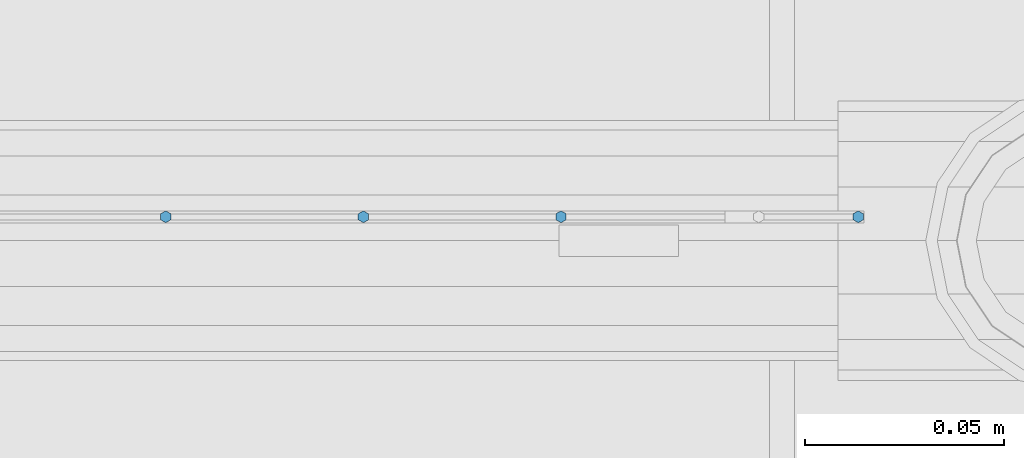
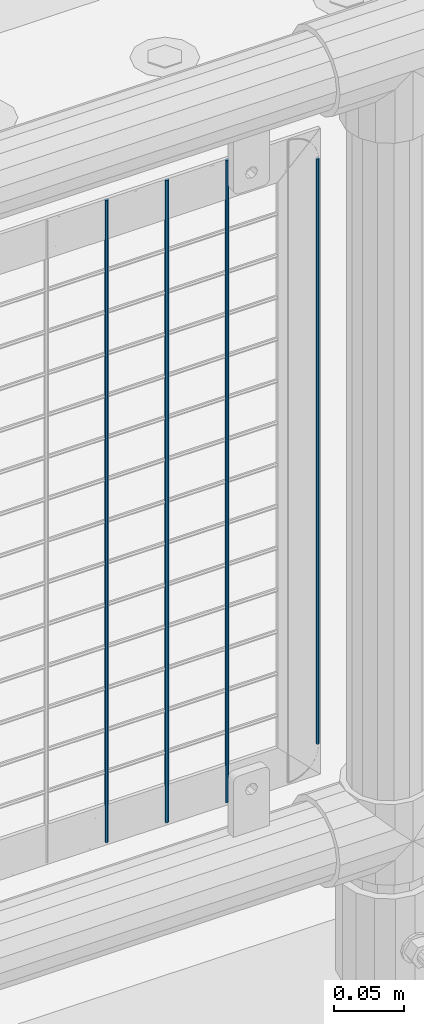
# One storey, part 87 of 257: 4 columns.
"""IFC2X3 building model written with IfcOpenShell, lengths in millimetres."""

from ifc_helpers import new_model, si_unit, frame, origin_with_axes, place, context, subcontext, project, spatial, faceted_brep, material, type_object, element, save


model = new_model("IFC2X3")

# Units and contexts
model_context = context("Model", 3, precision=1e-05, world=origin_with_axes())
body_context = subcontext(model_context, "Body", "Model", "MODEL_VIEW")
ifc_project = project(units=[si_unit("LENGTHUNIT", "METRE", prefix="MILLI"), si_unit("AREAUNIT", "SQUARE_METRE"), si_unit("VOLUMEUNIT", "CUBIC_METRE"), si_unit("MASSUNIT", "GRAM", prefix="KILO"), si_unit("TIMEUNIT", "SECOND"), si_unit("PLANEANGLEUNIT", "RADIAN"), si_unit("SOLIDANGLEUNIT", "STERADIAN"), si_unit("THERMODYNAMICTEMPERATUREUNIT", "DEGREE_CELSIUS"), si_unit("LUMINOUSINTENSITYUNIT", "LUMEN")], contexts=[model_context])

# Site, building, storey
site_placement = place(None, origin_with_axes())
site = spatial("IfcSite", under=ifc_project, at=site_placement, CompositionType="ELEMENT")
building_placement = place(site_placement, origin_with_axes())
building = spatial("IfcBuilding", under=site, at=building_placement, Name="Standard", CompositionType="ELEMENT")
storey_placement = place(building_placement, origin_with_axes())
storey = spatial("IfcBuildingStorey", under=building, at=storey_placement, Name="Undefined", CompositionType="ELEMENT", Elevation=0.0)

# Columns
ifc_material = material(Name="Misc_Undefined")
column_type = type_object("IfcColumnType", Name="D3", PredefinedType="NOTDEFINED")
for number, where, z_axis, x_axis in (
    (1, (52541.34, 10670.5, 353.020000000003), (-1.0, 0.0, 0.0), (0.0, 0.0, 1.0)),
    (2, (52491.685, 10670.5, 353.020000000003), (-1.0, 0.0, 0.0), (0.0, 0.0, 1.0)),
    (3, (52442.03, 10670.5, 353.020000000003), (-1.0, 0.0, 0.0), (0.0, 0.0, 1.0)),
):
    element("IfcColumn", number, at=place(storey_placement, frame(where, z_axis=z_axis, x_axis=x_axis)), inside=storey, type_object=column_type, material=ifc_material, ObjectType="D3", context=body_context, shape_type="Brep", body=[
        faceted_brep([(0.0, -1.5, -5.6843418860808e-14), (0.0, -0.750000000001819, -1.29903810567669), (560.0, -0.75, -1.29903810567339), (560.0, -1.5, 0.0), (7.27595761418343e-12, 0.749999999998181, -1.29903810567669), (560.0, 0.75, -1.29903810567339), (0.0, 1.5, -5.6843418860808e-14), (560.0, 1.5, 0.0), (7.27595761418343e-12, 0.749999999998181, 1.29903810567669), (560.0, 0.75, 1.29903810567339), (0.0, -0.750000000001819, 1.29903810567669), (560.0, -0.75, 1.29903810567339)], [[[0, 1, 2, 3]], [[1, 4, 5, 2]], [[4, 6, 7, 5]], [[6, 8, 9, 7]], [[8, 10, 11, 9]], [[10, 0, 3, 11]], [[5, 7, 9, 11, 3, 2]], [[10, 8, 6, 4, 1, 0]]]),
    ])
column_placement = place(storey_placement, frame((52616.0, 10670.5, 378.020000000003), z_axis=(-1.0, 0.0, 0.0), x_axis=(0.0, 0.0, 1.0)))
element("IfcColumn", 4, at=column_placement, inside=storey, type_object=column_type, material=ifc_material, ObjectType="D3", context=body_context, shape_type="Brep", body=[
    faceted_brep([(0.0, -1.5, -5.6843418860808e-14), (0.0, -0.750000000001819, -1.29903810567669), (510.0, -0.75, -1.29903810567339), (510.0, -1.5, 0.0), (7.27595761418343e-12, 0.749999999998181, -1.29903810567669), (510.0, 0.75, -1.29903810567339), (0.0, 1.5, -5.6843418860808e-14), (510.0, 1.5, 0.0), (7.27595761418343e-12, 0.749999999998181, 1.29903810567669), (510.0, 0.75, 1.29903810567339), (0.0, -0.750000000001819, 1.29903810567669), (510.0, -0.75, 1.29903810567339)], [[[0, 1, 2, 3]], [[1, 4, 5, 2]], [[4, 6, 7, 5]], [[6, 8, 9, 7]], [[8, 10, 11, 9]], [[10, 0, 3, 11]], [[5, 7, 9, 11, 3, 2]], [[10, 8, 6, 4, 1, 0]]]),
])

save(model, "model.ifc")
